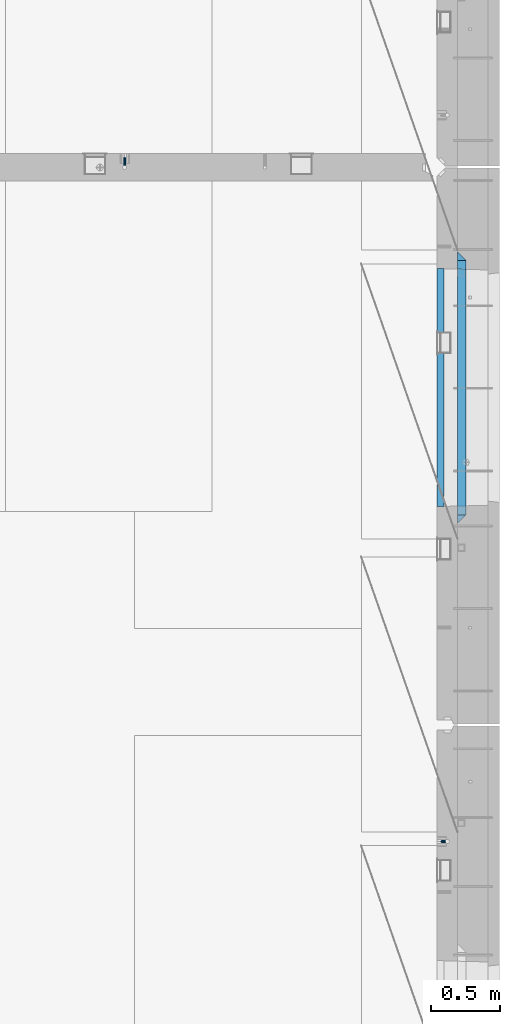
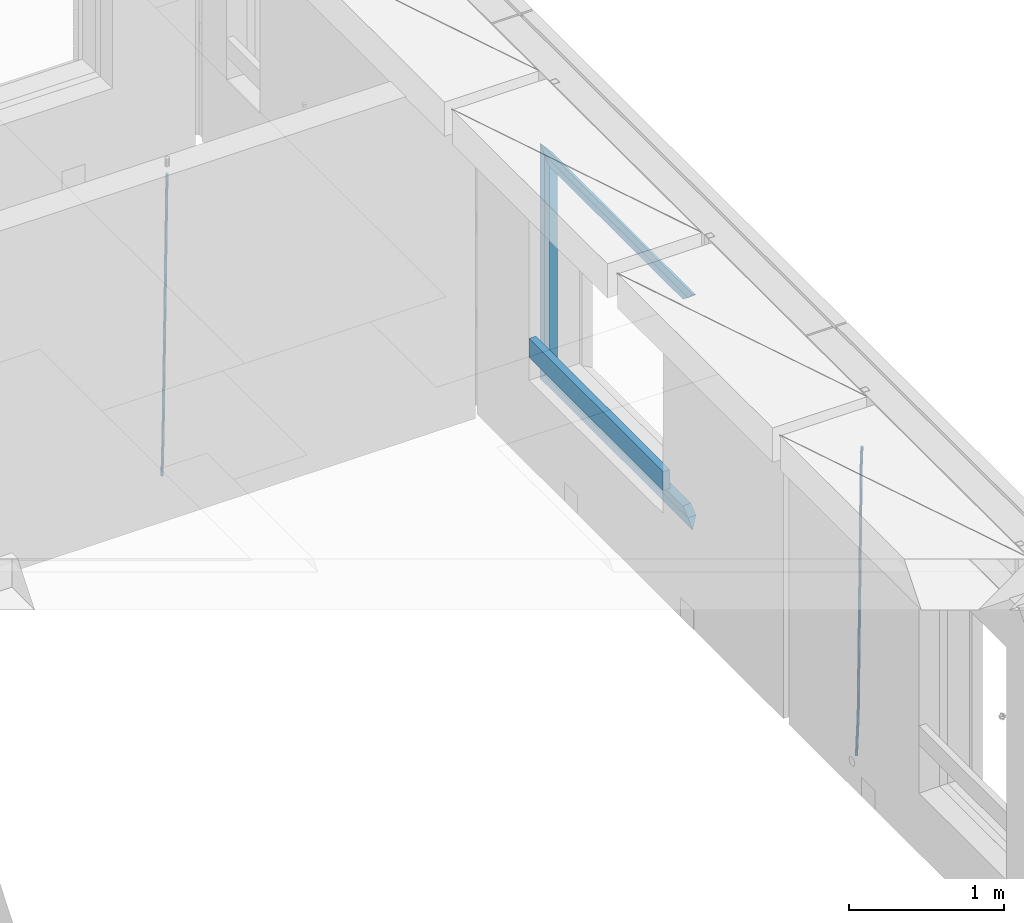
# One storey, part 132 of 350: 9 beams, 3 elements without a shape of their own.
"""IFC2X3 building model written with IfcOpenShell, lengths in millimetres."""

import ifcopenshell
import ifcopenshell.guid

model = None  # the IFC model being written
_history = None  # IfcOwnerHistory: only IFC2X3 demands one
_inside = {}  # id of a spatial element -> (the spatial element, [elements in it])
_under = {}  # id of a project, library or spatial element -> (it, [spatial elements below it])
_declared = {}  # id of a project -> (the project, [libraries it declares])
_typed = {}  # id of a type object -> (the type object, [elements of that type])
_made_of = {}  # id of a material, layer set ... -> (it, [elements and type objects made of it])


def new_model(schema):
    """Start an empty IFC model of exactly this schema.

    Asked for "IFC4X3", IfcOpenShell would pick the latest addendum, in which some entities
    have other attributes; the version numbers below select the first issue.
    IFC2X3 requires an IfcOwnerHistory on every rooted entity: one is made here for all.
    """
    global model, _history
    if schema == "IFC4X3":
        model = ifcopenshell.file(schema_version=(4, 3, 0, 0))
    else:
        model = ifcopenshell.file(schema=schema)
    _inside.clear()
    _under.clear()
    _declared.clear()
    _typed.clear()
    _made_of.clear()
    _history = None
    if model.schema == "IFC2X3":
        org = make("IfcOrganization", Name="unknown")
        user = make(
            "IfcPersonAndOrganization",
            ThePerson=make("IfcPerson", FamilyName="unknown"),
            TheOrganization=org,
        )
        app = make(
            "IfcApplication",
            ApplicationDeveloper=org,
            Version="unknown",
            ApplicationFullName="unknown",
            ApplicationIdentifier="unknown",
        )
        _history = make(
            "IfcOwnerHistory",
            OwningUser=user,
            OwningApplication=app,
            ChangeAction="ADDED",
            CreationDate=0,
        )
    return model


def make(cls, **values):
    """One entity of the class cls with the attributes given. An attribute that is None is left unset."""
    return model.create_entity(
        cls, **{name: value for name, value in values.items() if value is not None}
    )


def rooted(cls, **values):
    """An entity with a GlobalId (a new one), such as an element, a storey or a relation."""
    return make(cls, GlobalId=ifcopenshell.guid.new(), OwnerHistory=_history, **values)


def si_unit(unit_type, name, prefix=None):
    """IfcSIUnit, for example si_unit("LENGTHUNIT", "METRE", prefix="MILLI")."""
    return make("IfcSIUnit", UnitType=unit_type, Prefix=prefix, Name=name)


def assignment(units):
    """IfcUnitAssignment: the units of a project."""
    return None if units is None else make("IfcUnitAssignment", Units=units)


def point(xyz):
    """IfcCartesianPoint."""
    return None if xyz is None else make("IfcCartesianPoint", Coordinates=xyz)


def direction(xyz):
    """IfcDirection."""
    return None if xyz is None else make("IfcDirection", DirectionRatios=xyz)


def frame(location, z_axis=None, x_axis=None):
    """IfcAxis2Placement3D, a coordinate frame: its origin and axes. An axis left out is left unset."""
    return make(
        "IfcAxis2Placement3D",
        Location=point(location),
        Axis=direction(z_axis),
        RefDirection=direction(x_axis),
    )


def origin_with_axes():
    """The frame at (0, 0, 0) with the z axis (0, 0, 1) and the x axis (1, 0, 0) written out."""
    return frame((0.0, 0.0, 0.0), z_axis=(0.0, 0.0, 1.0), x_axis=(1.0, 0.0, 0.0))


def place(relative_to, where):
    """IfcLocalPlacement: puts the frame where relative to a parent placement (None: the world)."""
    return make(
        "IfcLocalPlacement", PlacementRelTo=relative_to, RelativePlacement=where
    )


def context(
    kind, dimensions, precision=None, world=None, true_north=None, identifier=None
):
    """IfcGeometricRepresentationContext, for example the 3D "Model" context."""
    return make(
        "IfcGeometricRepresentationContext",
        ContextIdentifier=identifier,
        ContextType=kind,
        CoordinateSpaceDimension=dimensions,
        Precision=precision,
        WorldCoordinateSystem=world,
        TrueNorth=true_north,
    )


def subcontext(parent, identifier, kind, view, scale=None):
    """IfcGeometricRepresentationSubContext, for example "Body" below "Model"."""
    return make(
        "IfcGeometricRepresentationSubContext",
        ContextIdentifier=identifier,
        ContextType=kind,
        ParentContext=parent,
        TargetScale=scale,
        TargetView=view,
    )


def project(units=None, contexts=None):
    """IfcProject with its units and contexts."""
    return rooted(
        "IfcProject",
        Name="project",
        RepresentationContexts=contexts,
        UnitsInContext=assignment(units),
    )


def spatial(cls, under=None, at=None, **own):
    """A site, building, storey or space (cls), placed at a placement, below another one or the project."""
    s = rooted(cls, ObjectPlacement=at, **own)
    if under is not None:
        _under.setdefault(under.id(), (under, []))[1].append(s)
    return s


def faces_of(points, faces, orient=None, outer=None):
    """IfcFace entities. A face is a list of loops; a loop is a list of indices into points, from 0.

    orient and outer hold one flag for each loop. By default every Orientation is true, the
    first loop of a face is its IfcFaceOuterBound and the others are IfcFaceBound.
    """
    made = []
    for i, loops in enumerate(faces):
        bounds = []
        for j, loop in enumerate(loops):
            is_outer = j == 0 if outer is None else outer[i][j]
            bounds.append(
                make(
                    "IfcFaceOuterBound" if is_outer else "IfcFaceBound",
                    Bound=make("IfcPolyLoop", Polygon=[points[k] for k in loop]),
                    Orientation=True if orient is None else orient[i][j],
                )
            )
        made.append(make("IfcFace", Bounds=bounds))
    return made


def faceted_brep(points, faces, orient=None, outer=None, voids=None):
    """IfcFacetedBrep: a solid bounded by flat faces; with voids (closed shells), ...WithVoids."""
    shared = [point(p) for p in points]
    hull = make("IfcClosedShell", CfsFaces=faces_of(shared, faces, orient, outer))
    if voids is None:
        return make("IfcFacetedBrep", Outer=hull)
    return make(
        "IfcFacetedBrepWithVoids",
        Outer=hull,
        Voids=[
            make(cls, CfsFaces=faces_of(shared, fs, o, b)) for cls, fs, o, b in voids
        ],
    )


def shape(context_of_items, identifier, shape_type, items):
    """IfcShapeRepresentation: the items that make up one representation, for example the "Body"."""
    return make(
        "IfcShapeRepresentation",
        ContextOfItems=context_of_items,
        RepresentationIdentifier=identifier,
        RepresentationType=shape_type,
        Items=items,
    )


def material(Name=None, Category=None):
    """IfcMaterial."""
    return make("IfcMaterial", Name=Name, Category=Category)


def made_of(thing, what):
    """Note that an element or type object is made of a material, layer set ...; save() writes the relation."""
    if what is not None:
        _made_of.setdefault(what.id(), (what, []))[1].append(thing)
    return thing


def type_object(cls, material=None, **own):
    """A type object (cls), such as IfcWallType, which elements share."""
    return made_of(rooted(cls, **own), material)


def element(
    cls,
    number,
    at=None,
    inside=None,
    cuts=None,
    type_object=None,
    material=None,
    context=None,
    identifier="Body",
    shape_type=None,
    held_by="IfcProductDefinitionShape",
    body=None,
    shapes=None,
    **own,
):
    """One element of the class cls, such as IfcWall. Its Tag is "e" and its number.

    at: its placement. inside: the storey or other place that contains it. cuts: it is an
    opening in that element (IfcRelVoidsElement). A single representation is given by context,
    identifier, shape_type and body (its items); several are given by shapes. held_by: the class
    of the entity that holds the representations. save() writes the other relations.
    """
    e = rooted(cls, Tag="e%d" % number, ObjectPlacement=at, **own)
    if body is not None:
        shapes = [shape(context, identifier, shape_type, body)]
    if shapes is not None:
        e.Representation = make(held_by, Representations=shapes)
    if inside is not None:
        _inside.setdefault(inside.id(), (inside, []))[1].append(e)
    if cuts is not None:
        rooted(
            "IfcRelVoidsElement", RelatingBuildingElement=cuts, RelatedOpeningElement=e
        )
    if type_object is not None:
        _typed.setdefault(type_object.id(), (type_object, []))[1].append(e)
    return made_of(e, material)


def aggregate(whole, parts):
    """IfcRelAggregates: a whole, such as a stair, and the parts it consists of."""
    return rooted("IfcRelAggregates", RelatingObject=whole, RelatedObjects=parts)


def save(model, path):
    """Write the relations noted so far, then the file.

    IfcRelAggregates (storeys below a building ...), IfcRelContainedInSpatialStructure (elements
    in a storey), IfcRelDefinesByType, IfcRelAssociatesMaterial and IfcRelDeclares: one each for
    every whole, place, type object, material and project.
    """
    for whole, parts in _under.values():
        aggregate(whole, parts)
    for where, things in _inside.values():
        rooted(
            "IfcRelContainedInSpatialStructure",
            RelatedElements=things,
            RelatingStructure=where,
        )
    for kind, things in _typed.values():
        rooted("IfcRelDefinesByType", RelatedObjects=things, RelatingType=kind)
    for what, things in _made_of.values():
        rooted("IfcRelAssociatesMaterial", RelatedObjects=things, RelatingMaterial=what)
    for by, libraries in _declared.values():
        rooted("IfcRelDeclares", RelatingContext=by, RelatedDefinitions=libraries)
    model.write(path)


model = new_model("IFC2X3")

# Units and contexts
model_context = context("Model", 3, precision=1e-05, world=origin_with_axes())
body_context = subcontext(model_context, "Body", "Model", "MODEL_VIEW")
ifc_project = project(units=[si_unit("LENGTHUNIT", "METRE", prefix="MILLI"), si_unit("AREAUNIT", "SQUARE_METRE"), si_unit("VOLUMEUNIT", "CUBIC_METRE"), si_unit("MASSUNIT", "GRAM", prefix="KILO"), si_unit("TIMEUNIT", "SECOND"), si_unit("PLANEANGLEUNIT", "RADIAN"), si_unit("SOLIDANGLEUNIT", "STERADIAN"), si_unit("THERMODYNAMICTEMPERATUREUNIT", "DEGREE_CELSIUS"), si_unit("LUMINOUSINTENSITYUNIT", "LUMEN")], contexts=[model_context])

# Site, building, storey
site_placement = place(None, origin_with_axes())
site = spatial("IfcSite", under=ifc_project, at=site_placement, CompositionType="ELEMENT")
building_placement = place(site_placement, origin_with_axes())
building = spatial("IfcBuilding", under=site, at=building_placement, CompositionType="ELEMENT")
storey_placement = place(building_placement, origin_with_axes())
storey = spatial("IfcBuildingStorey", under=building, at=storey_placement, Name="2", CompositionType="ELEMENT", Elevation=0.0)

# Assembly, beam
assembly_1_placement = place(storey_placement, origin_with_axes())
assembly_1 = element("IfcElementAssembly", 1, at=assembly_1_placement, inside=storey, AssemblyPlace="NOTDEFINED", PredefinedType="REINFORCEMENT_UNIT")
ifc_material_1 = material()
beam_type_1 = type_object("IfcBeamType", Name="D20", PredefinedType="NOTDEFINED")
beam_1_placement = place(assembly_1_placement, frame((32639.9999999961, 17044.9997581385, 84990.0), z_axis=(0.00020576299992186, -0.999642804629538, -0.0267249099901004), x_axis=(-4.30000201928125e-08, -0.0267249099948059, 0.999642825806181)))
beam_1 = element("IfcBeam", 2, at=beam_1_placement, type_object=beam_type_1, material=ifc_material_1, Name="JM20", ObjectType="D20", context=body_context, shape_type="Brep", body=[
    faceted_brep([(0.0, -10.0, 0.0), (-4.19531716033816e-08, -7.07106781186667, -7.07106781187031), (60.4266690400545, -7.0710677960451, -7.07106780570757), (60.4266690441291, -9.99999998418934, 6.15546014159918e-09), (0.0, 0.0, -10.0), (60.426669036824, 1.58106558956206e-08, -9.99999999384454), (4.196772351861e-08, 7.07106781186303, -7.07106781186667), (60.4266690363438, 7.07106782768096, -7.07106780570757), (0.0, 10.0, 0.0), (60.4266690388904, 10.0000000158179, 6.15182216279209e-09), (4.196772351861e-08, 7.07106781185939, 7.07106781185939), (60.4266690429649, 7.07106782768096, 7.07106781802577), (0.0, 0.0, 10.0), (60.4266690461809, 1.58179318532348e-08, 10.0000000061555), (-4.19531716033816e-08, -7.07106781187031, 7.07106781185939), (60.4266690466611, -7.07106779605238, 7.07106781802213), (61.0378400410118, -7.07106779588503, -7.07106780564936), (60.991799419251, -9.99999998403655, 6.21366780251265e-09), (61.0569027789461, 1.5985278878361e-08, -9.99999999378269), (61.0378209396877, 7.07106782784831, -7.07106780564936), (60.9917724058905, 10.0000000159635, 6.21366780251265e-09), (60.9457317841297, 7.07106782781193, 7.0710678180767), (60.9266690461809, 1.59488990902901e-08, 10.0000000062028), (60.9457508854539, -7.07106779591413, 7.0710678180767), (61.6489592143771, -7.07106614513759, -7.06310863441468), (61.5568818710308, -9.9999984576425, 0.00735959856683621), (61.6870830769039, 1.71821739058942e-06, -9.99179257185824), (61.6489210170112, 7.07106947854481, -7.06310888312146), (61.556827851804, 10.0000015422847, 0.00735924683976918), (61.4647505084577, 7.07106922979438, 7.07782747982128), (61.4266266459163, 1.36643211590126e-06, 10.0065114172685), (61.464788705809, -7.07106639389531, 7.07782772852806), (176.543135720174, -7.07075579406956, -5.56673531796696), (176.451058376813, -9.99968810657447, 1.50373291501455), (176.581259582701, 0.000312069292704109, -8.49541925541052), (176.543097522794, 7.07137982961285, -5.56673556667374), (176.451004357587, 10.00031189336, 1.50373256329476), (176.35892701424, 7.07137958085514, 8.57420079627263), (176.320803151699, 0.000311717507429421, 11.5028847337162), (176.358965211621, -7.07075604281999, 8.57420104497578), (177.098753836006, -7.07075429323595, -5.55949898843028), (176.98362511232, -9.99968666800123, 1.510669025065), (177.146421932586, 0.000313595905026887, -8.48805862247536), (177.098706077581, 7.07138133041735, -5.55949936166144), (176.983557571715, 10.0003133318824, 1.51066849724157), (176.868428848029, 7.07138095712435, 8.58083651073321), (176.820760751449, 0.000313067976094317, 11.5093961447819), (176.868476606425, -7.07075466652896, 8.58083688396073), (177.654312950661, -7.07075204110879, -5.54863964998367), (177.516135294456, -9.99968450931192, 1.52107783331303), (177.711524267797, 0.000315886711177882, -8.47701274570863), (177.654255632195, 7.07138358250813, -5.54864021007961), (177.516054233929, 10.0003154905207, 1.5210770412159), (177.377876577739, 7.0713830223176, 8.59079452451624), (177.320665260588, 0.000315094497636892, 11.5191676202448), (177.377933896176, -7.07075260129932, 8.59079508461218), (299.499456785634, -7.07025810522464, -3.16697112782276), (299.361279129444, -9.99919057342777, 3.90274635547394), (299.556668102785, 0.000809822595329024, -6.09534422354773), (299.499399467197, 7.07187751838501, -3.1669716879187), (299.361198068917, 10.0008094264049, 3.90274556338045), (299.223020412712, 7.07187695819448, 10.9724630466735), (299.165809095575, 0.000809030381788034, 13.9008361423985), (299.223077731163, -7.07025866542244, 10.9724636067695), (300.03174732349, -7.07025594743027, -3.15656661289177), (299.971788958996, -9.99918809853989, 3.91467979818117), (300.056572611924, 0.000811849109595641, -6.08557274808481), (300.031722507032, 7.07187967631762, -3.15656653768019), (299.971753863239, 10.0008119014747, 3.91467990454839), (299.91179549876, 7.07187975035777, 10.9859263156177), (299.886970210311, 0.000811953817901667, 13.9149324508144), (299.911820315203, -7.0702558733974, 10.9859262404061), (300.564137759997, -7.07025623699155, -3.15794273276697), (300.582413367199, -9.99918843065097, 3.91310145956595), (300.556570941641, 0.000811577163403854, -6.0868651410201), (300.564145451674, 7.07187938674906, -3.15794274158179), (300.582424244858, 10.0008115693345, 3.91310144710224), (300.600699852032, 7.07187937566778, 10.9841456394352), (300.608266670402, 0.000811561512819026, 13.9130680476919), (300.600692160384, -7.07025624805829, 10.98414564825), (2294.16589219622, -7.0713405251372, -8.31099358700158), (2294.1841678034, -10.0002727187966, -1.23994939466866), (2294.15832537785, -0.000272710982244462, -11.2399159952547), (2294.16589988787, 7.07079509858886, -8.31099359582004), (2294.18417868105, 9.99972728118883, -1.23994940713601), (2294.20245428824, 7.07079508752213, 5.83109478519327), (2294.2100211066, -0.00027272663282929, 8.76001719345368), (2294.20244659658, -7.07134053620393, 5.83109479401173), (2294.7782683276, -7.07134085819416, -8.31257645345977), (2294.72126025338, -10.000273010919, -1.24133766827799), (2294.84007459224, -0.000273081772320438, -11.2416781768807), (2294.87047377572, 7.07079471537872, -8.31281477453012), (2294.85165844864, 9.9997269181622, -1.24167470516841), (2294.7946503744, 7.07079476544459, 5.82956408001337), (2294.73284410976, -0.000273010977252852, 8.75866580342336), (2294.7024449263, -7.07134080815013, 5.82980240107645), (2295.39054023061, -7.0793250091956, -8.30442771922026), (2295.25826128852, -10.0072756143927, -1.23419071494573), (2295.52170777075, -0.00916171800054144, -11.2326063125765), (2295.57492774284, 7.06160849139269, -8.30343918807193), (2295.51902460904, 9.99102432676591, -1.23279272078435), (2295.38674566693, 7.06307372157607, 5.83744428349019), (2295.25557812679, -0.0070895696117077, 8.76562287684646), (2295.20235815471, -7.07785977901949, 5.83645575234186), (2317.1947101649, -7.36365585014573, -8.01423575520312), (2317.06243122277, -10.2916064553428, -0.94399875092131), (2317.32587770502, -0.293492558957951, -10.9424143485521), (2317.37909767711, 6.77727765044983, -8.01324722405116), (2317.32319454331, 9.70669348581578, -0.942600756767206), (2317.1909156012, 6.77874288063322, 6.12763624751096), (2317.05974806109, -0.291420410569117, 9.0558148408636), (2317.00652808898, -7.36219061996962, 6.12664771636264), (2317.83015404257, -7.37194216843636, -8.00577862486898), (2317.72252095213, -10.300214160583, -0.935213608652703), (2317.90419832576, -0.301033978277701, -10.9347174723516), (2317.90127966482, 6.77046829039318, -8.00629749759901), (2317.82310777172, 9.70017451494641, -0.935947405505431), (2317.71547468127, 6.77190252279979, 6.13461761071085), (2317.64143039809, -0.29900566735887, 9.06355645819713), (2317.64434905903, -7.37050793602975, 6.13513648344451), (2318.46565174212, -7.3700661537805, -7.99751648408346), (2318.38266643914, -10.2982456018653, -0.926623872735945), (2318.48256818345, -0.299336209594912, -10.9272153854981), (2318.42350634121, 6.77200652527245, -7.99954269419686), (2318.32306384158, 9.70166538090416, -0.929489366557391), (2318.2400785386, 6.77348593281204, 6.14140324480104), (2318.22316209726, -0.297244011366274, 9.07110214621207), (2318.2822239395, -7.36858674623363, 6.1434294549108), (2418.48643733139, -7.07180401323421, -6.70013846199799), (2418.4034520284, -9.99998346132634, 0.370754149349523), (2418.5033537727, -0.00107406904135132, -9.62983736341266), (2418.44429193046, 7.07026866581873, -6.70216467211139), (2418.34384943081, 9.99992752145772, 0.367888655531715), (2418.26086412782, 7.0717480733656, 7.43878126688651), (2418.24394768651, 0.00101812917273492, 10.3684801682975), (2418.30300952874, -7.07032460568735, 7.44080747699627)], [[[0, 1, 2, 3]], [[1, 4, 5, 2]], [[4, 6, 7, 5]], [[6, 8, 9, 7]], [[8, 10, 11, 9]], [[10, 12, 13, 11]], [[12, 14, 15, 13]], [[14, 0, 3, 15]], [[14, 12, 10, 8, 6, 4, 1, 0]], [[3, 2, 16, 17]], [[2, 5, 18, 16]], [[5, 7, 19, 18]], [[7, 9, 20, 19]], [[9, 11, 21, 20]], [[11, 13, 22, 21]], [[13, 15, 23, 22]], [[15, 3, 17, 23]], [[17, 16, 24, 25]], [[16, 18, 26, 24]], [[18, 19, 27, 26]], [[19, 20, 28, 27]], [[20, 21, 29, 28]], [[21, 22, 30, 29]], [[22, 23, 31, 30]], [[23, 17, 25, 31]], [[25, 24, 32, 33]], [[24, 26, 34, 32]], [[26, 27, 35, 34]], [[27, 28, 36, 35]], [[28, 29, 37, 36]], [[29, 30, 38, 37]], [[30, 31, 39, 38]], [[31, 25, 33, 39]], [[33, 32, 40, 41]], [[32, 34, 42, 40]], [[34, 35, 43, 42]], [[35, 36, 44, 43]], [[36, 37, 45, 44]], [[37, 38, 46, 45]], [[38, 39, 47, 46]], [[39, 33, 41, 47]], [[41, 40, 48, 49]], [[40, 42, 50, 48]], [[42, 43, 51, 50]], [[43, 44, 52, 51]], [[44, 45, 53, 52]], [[45, 46, 54, 53]], [[46, 47, 55, 54]], [[47, 41, 49, 55]], [[49, 48, 56, 57]], [[48, 50, 58, 56]], [[50, 51, 59, 58]], [[51, 52, 60, 59]], [[52, 53, 61, 60]], [[53, 54, 62, 61]], [[54, 55, 63, 62]], [[55, 49, 57, 63]], [[57, 56, 64, 65]], [[56, 58, 66, 64]], [[58, 59, 67, 66]], [[59, 60, 68, 67]], [[60, 61, 69, 68]], [[61, 62, 70, 69]], [[62, 63, 71, 70]], [[63, 57, 65, 71]], [[65, 64, 72, 73]], [[64, 66, 74, 72]], [[66, 67, 75, 74]], [[67, 68, 76, 75]], [[68, 69, 77, 76]], [[69, 70, 78, 77]], [[70, 71, 79, 78]], [[71, 65, 73, 79]], [[73, 72, 80, 81]], [[72, 74, 82, 80]], [[74, 75, 83, 82]], [[75, 76, 84, 83]], [[76, 77, 85, 84]], [[77, 78, 86, 85]], [[78, 79, 87, 86]], [[79, 73, 81, 87]], [[81, 80, 88, 89]], [[80, 82, 90, 88]], [[82, 83, 91, 90]], [[83, 84, 92, 91]], [[84, 85, 93, 92]], [[85, 86, 94, 93]], [[86, 87, 95, 94]], [[87, 81, 89, 95]], [[89, 88, 96, 97]], [[88, 90, 98, 96]], [[90, 91, 99, 98]], [[91, 92, 100, 99]], [[92, 93, 101, 100]], [[93, 94, 102, 101]], [[94, 95, 103, 102]], [[95, 89, 97, 103]], [[97, 96, 104, 105]], [[96, 98, 106, 104]], [[98, 99, 107, 106]], [[99, 100, 108, 107]], [[100, 101, 109, 108]], [[101, 102, 110, 109]], [[102, 103, 111, 110]], [[103, 97, 105, 111]], [[105, 104, 112, 113]], [[104, 106, 114, 112]], [[106, 107, 115, 114]], [[107, 108, 116, 115]], [[108, 109, 117, 116]], [[109, 110, 118, 117]], [[110, 111, 119, 118]], [[111, 105, 113, 119]], [[113, 112, 120, 121]], [[112, 114, 122, 120]], [[114, 115, 123, 122]], [[115, 116, 124, 123]], [[116, 117, 125, 124]], [[117, 118, 126, 125]], [[118, 119, 127, 126]], [[119, 113, 121, 127]], [[121, 120, 128, 129]], [[120, 122, 130, 128]], [[122, 123, 131, 130]], [[123, 124, 132, 131]], [[124, 125, 133, 132]], [[125, 126, 134, 133]], [[126, 127, 135, 134]], [[127, 121, 129, 135]], [[130, 131, 132, 133, 134, 135, 129, 128]]]),
])
aggregate(assembly_1, [beam_1])

assembly_2_placement = place(storey_placement, origin_with_axes())
assembly_2 = element("IfcElementAssembly", 3, at=assembly_2_placement, inside=storey, AssemblyPlace="NOTDEFINED", PredefinedType="REINFORCEMENT_UNIT")
beam_2_placement = place(assembly_2_placement, frame((34944.9999977209, 12080.9402860984, 84990.0), z_axis=(0.999642804629538, 0.000205762999925497, -0.0267249099901003), x_axis=(0.0267249109941254, -4.30000210532798e-08, 0.999642825779465)))
beam_2 = element("IfcBeam", 4, at=beam_2_placement, type_object=beam_type_1, material=ifc_material_1, Name="JM20", ObjectType="D20", context=body_context, shape_type="Brep", body=[
    faceted_brep([(0.0, -10.0, 0.0), (-4.19531716033816e-08, -7.07106781186667, -7.07106781187031), (60.4266690400545, -7.0710677960451, -7.07106780570757), (60.4266690441291, -9.99999998418934, 6.15546014159918e-09), (0.0, 0.0, -10.0), (60.426669036824, 1.58106558956206e-08, -9.99999999384454), (4.196772351861e-08, 7.07106781186303, -7.07106781186667), (60.4266690363438, 7.07106782768096, -7.07106780570757), (0.0, 10.0, 0.0), (60.4266690388904, 10.0000000158179, 6.15182216279209e-09), (4.196772351861e-08, 7.07106781185939, 7.07106781185939), (60.4266690429649, 7.07106782768096, 7.07106781802577), (0.0, 0.0, 10.0), (60.4266690461809, 1.58179318532348e-08, 10.0000000061555), (-4.19531716033816e-08, -7.07106781187031, 7.07106781185939), (60.4266690466611, -7.07106779605238, 7.07106781802213), (61.0378400410118, -7.07106779588503, -7.07106780564936), (60.991799419251, -9.99999998403655, 6.21366780251265e-09), (61.0569027789461, 1.5985278878361e-08, -9.99999999378269), (61.0378209396877, 7.07106782784831, -7.07106780564936), (60.9917724058905, 10.0000000159635, 6.21366780251265e-09), (60.9457317841297, 7.07106782781193, 7.0710678180767), (60.9266690461809, 1.59488990902901e-08, 10.0000000062028), (60.9457508854539, -7.07106779591413, 7.0710678180767), (61.6489592143771, -7.07106614513759, -7.06310863441468), (61.5568818710308, -9.9999984576425, 0.00735959856683621), (61.6870830769039, 1.71821739058942e-06, -9.99179257185824), (61.6489210170112, 7.07106947854481, -7.06310888312146), (61.556827851804, 10.0000015422847, 0.00735924683976918), (61.4647505084577, 7.07106922979438, 7.07782747982128), (61.4266266459163, 1.36643211590126e-06, 10.0065114172685), (61.464788705809, -7.07106639389531, 7.07782772852806), (176.543135720174, -7.07075579406956, -5.56673531796696), (176.451058376813, -9.99968810657447, 1.50373291501455), (176.581259582701, 0.000312069292704109, -8.49541925541052), (176.543097522794, 7.07137982961285, -5.56673556667374), (176.451004357587, 10.00031189336, 1.50373256329476), (176.35892701424, 7.07137958085514, 8.57420079627263), (176.320803151699, 0.000311717507429421, 11.5028847337162), (176.358965211621, -7.07075604281999, 8.57420104497578), (177.098753836006, -7.07075429323595, -5.55949898843028), (176.98362511232, -9.99968666800123, 1.510669025065), (177.146421932586, 0.000313595905026887, -8.48805862247536), (177.098706077581, 7.07138133041735, -5.55949936166144), (176.983557571715, 10.0003133318824, 1.51066849724157), (176.868428848029, 7.07138095712435, 8.58083651073321), (176.820760751449, 0.000313067976094317, 11.5093961447819), (176.868476606425, -7.07075466652896, 8.58083688396073), (177.654312950661, -7.07075204110879, -5.54863964998367), (177.516135294456, -9.99968450931192, 1.52107783331303), (177.711524267797, 0.000315886711177882, -8.47701274570863), (177.654255632195, 7.07138358250813, -5.54864021007961), (177.516054233929, 10.0003154905207, 1.5210770412159), (177.377876577739, 7.0713830223176, 8.59079452451624), (177.320665260588, 0.000315094497636892, 11.5191676202448), (177.377933896176, -7.07075260129932, 8.59079508461218), (299.436796249574, -7.07025836271714, -3.1681962331204), (299.298618593355, -9.99919083092027, 3.90152125031091), (299.494007566798, 0.000809565110102994, -6.09656932889993), (299.436738931283, 7.07187726089978, -3.16819679320906), (299.298537533061, 10.0008091689197, 3.90152045822106), (299.160359876842, 7.07187670072017, 10.9712379416487), (299.103148559603, 0.000808772889286047, 13.8996110374392), (299.160417195119, -7.07025892290039, 10.9712385017483), (299.98743051647, -7.07025613056248, -3.15743315966392), (299.971788958996, -9.99918809853989, 3.91467979818117), (299.993912075952, 0.000811591617093654, -6.08679785393178), (299.987423933868, 7.07187949325817, -3.1574327280432), (299.971753863239, 10.0008119014747, 3.91467990454839), (299.95611230444, 7.07187992653053, 10.9867922621015), (299.949630744944, 0.000812204350950196, 13.9161569563694), (299.956118887014, -7.07025569729012, 10.9867918304735), (300.538107039494, -7.07025785017686, -3.16575821840888), (300.644985195438, -9.99919020432935, 3.90450175465594), (300.493854948218, 0.000810030429420294, -6.09435592770024), (300.538151196495, 7.071877773491, -3.16575855385963), (300.645047642858, 10.0008097955724, 3.90450128024895), (300.751925798773, 7.07187744142357, 10.9747612533101), (300.796177890064, 0.000809560813650023, 13.9033589625978), (300.751881641787, -7.07025818224065, 10.9747615887682), (2293.36490490142, -7.07648090940347, -33.2930642912361), (2293.47178305736, -10.0054132635523, -26.2228043181785), (2293.32065281013, -0.00541302880083094, -36.2216620005347), (2293.36494905842, 7.06565471425711, -33.2930646266868), (2293.47184550477, 9.99458673634581, -26.2228047925819), (2293.57872366071, 7.06565438219332, -19.1525448195243), (2293.62297575199, -0.00541349841296324, -16.2239471102366), (2293.57867950371, -7.0764812414709, -19.1525444840736), (2294.0658245362, -7.07648309818615, -33.3036607065333), (2294.05312277409, -10.0054150789219, -26.2315929392535), (2294.10928714235, -0.00541549149056664, -36.2335844756526), (2294.15805078732, 7.06565223761572, -33.3050546393533), (2294.18355038921, 9.99458451388637, -26.2335642579346), (2294.17084862708, 7.06565253314329, -19.1614964906439), (2294.12738602093, -0.00541507354500936, -16.2315727215355), (2294.07862237596, -7.07648280265857, -19.1601025578348), (2294.76670261032, -7.08562269121467, -33.294332712383), (2294.63442802057, -10.0129954178956, -26.2238563411993), (2294.89787471293, -0.0156988342423574, -36.2230891548279), (2294.95110548967, 7.05531064255774, -33.2944998654275), (2294.89521307347, 9.98530428734011, -26.2240927312887), (2294.76293848372, 7.0579315606592, -19.1536163601049), (2294.63176638114, -0.0119922963167483, -16.2248599176673), (2294.57853560438, -7.08300177311321, -19.1534492070678), (2316.52657204497, -7.36937582653991, -33.0047303660212), (2316.39429745522, -10.2967485532172, -25.9342539948302), (2316.65774414754, -0.299451969567599, -35.9334868084661), (2316.7109749243, 6.7715575072325, -33.0048975190657), (2316.65508250811, 9.70155115201487, -25.9344903849269), (2316.52280791836, 6.7741784253376, -18.8640140137468), (2316.39163581574, -0.295745431634714, -15.9352575713092), (2316.33840503903, -7.36675490843481, -18.863846860706), (2317.16202064224, -7.37766220584308, -32.9962731735213), (2317.05438744847, -10.3053562613532, -25.9254688497131), (2317.23607125619, -0.306993473008333, -35.925789846493), (2317.23316144495, 6.76474808850253, -32.9979477328052), (2317.15499573652, 9.6950321815566, -25.9278370341635), (2317.04736254275, 6.7673381260538, -18.8570327103698), (2316.97331192881, -0.303330606784584, -15.9275160373909), (2316.97622174003, -7.37507216829545, -18.8553581510787), (2317.79752306276, -7.37578610372293, -32.9880110666527), (2317.71453320107, -10.3033876998124, -25.9168792378296), (2317.81444760226, -0.305295583297266, -35.918287695793), (2317.75539265381, 6.76628640723357, -32.9911928173897), (2317.65495180529, 9.69652304524061, -25.9213789128698), (2317.5719619436, 6.76892144914746, -18.8502470840467), (2317.55503740412, -0.301569071270933, -15.9199704549137), (2317.61409235255, -7.3731510618054, -18.847065333317), (2417.8183084176, -7.07752398473531, -31.6906369377139), (2417.73531855589, -10.0051255808248, -24.6195051088798), (2417.83523295709, -0.007033464313281, -34.6209135668432), (2417.77617800863, 7.06454852621755, -31.6938186884508), (2417.67573716014, 9.99478516423187, -24.6240047839383), (2417.59274729842, 7.06718356813872, -17.5528729551006), (2417.57582275895, -0.00330695228694822, -14.6225963259749), (2417.6348777074, -7.07488894281778, -17.5496912043673)], [[[0, 1, 2, 3]], [[1, 4, 5, 2]], [[4, 6, 7, 5]], [[6, 8, 9, 7]], [[8, 10, 11, 9]], [[10, 12, 13, 11]], [[12, 14, 15, 13]], [[14, 0, 3, 15]], [[14, 12, 10, 8, 6, 4, 1, 0]], [[3, 2, 16, 17]], [[2, 5, 18, 16]], [[5, 7, 19, 18]], [[7, 9, 20, 19]], [[9, 11, 21, 20]], [[11, 13, 22, 21]], [[13, 15, 23, 22]], [[15, 3, 17, 23]], [[17, 16, 24, 25]], [[16, 18, 26, 24]], [[18, 19, 27, 26]], [[19, 20, 28, 27]], [[20, 21, 29, 28]], [[21, 22, 30, 29]], [[22, 23, 31, 30]], [[23, 17, 25, 31]], [[25, 24, 32, 33]], [[24, 26, 34, 32]], [[26, 27, 35, 34]], [[27, 28, 36, 35]], [[28, 29, 37, 36]], [[29, 30, 38, 37]], [[30, 31, 39, 38]], [[31, 25, 33, 39]], [[33, 32, 40, 41]], [[32, 34, 42, 40]], [[34, 35, 43, 42]], [[35, 36, 44, 43]], [[36, 37, 45, 44]], [[37, 38, 46, 45]], [[38, 39, 47, 46]], [[39, 33, 41, 47]], [[41, 40, 48, 49]], [[40, 42, 50, 48]], [[42, 43, 51, 50]], [[43, 44, 52, 51]], [[44, 45, 53, 52]], [[45, 46, 54, 53]], [[46, 47, 55, 54]], [[47, 41, 49, 55]], [[49, 48, 56, 57]], [[48, 50, 58, 56]], [[50, 51, 59, 58]], [[51, 52, 60, 59]], [[52, 53, 61, 60]], [[53, 54, 62, 61]], [[54, 55, 63, 62]], [[55, 49, 57, 63]], [[57, 56, 64, 65]], [[56, 58, 66, 64]], [[58, 59, 67, 66]], [[59, 60, 68, 67]], [[60, 61, 69, 68]], [[61, 62, 70, 69]], [[62, 63, 71, 70]], [[63, 57, 65, 71]], [[65, 64, 72, 73]], [[64, 66, 74, 72]], [[66, 67, 75, 74]], [[67, 68, 76, 75]], [[68, 69, 77, 76]], [[69, 70, 78, 77]], [[70, 71, 79, 78]], [[71, 65, 73, 79]], [[73, 72, 80, 81]], [[72, 74, 82, 80]], [[74, 75, 83, 82]], [[75, 76, 84, 83]], [[76, 77, 85, 84]], [[77, 78, 86, 85]], [[78, 79, 87, 86]], [[79, 73, 81, 87]], [[81, 80, 88, 89]], [[80, 82, 90, 88]], [[82, 83, 91, 90]], [[83, 84, 92, 91]], [[84, 85, 93, 92]], [[85, 86, 94, 93]], [[86, 87, 95, 94]], [[87, 81, 89, 95]], [[89, 88, 96, 97]], [[88, 90, 98, 96]], [[90, 91, 99, 98]], [[91, 92, 100, 99]], [[92, 93, 101, 100]], [[93, 94, 102, 101]], [[94, 95, 103, 102]], [[95, 89, 97, 103]], [[97, 96, 104, 105]], [[96, 98, 106, 104]], [[98, 99, 107, 106]], [[99, 100, 108, 107]], [[100, 101, 109, 108]], [[101, 102, 110, 109]], [[102, 103, 111, 110]], [[103, 97, 105, 111]], [[105, 104, 112, 113]], [[104, 106, 114, 112]], [[106, 107, 115, 114]], [[107, 108, 116, 115]], [[108, 109, 117, 116]], [[109, 110, 118, 117]], [[110, 111, 119, 118]], [[111, 105, 113, 119]], [[113, 112, 120, 121]], [[112, 114, 122, 120]], [[114, 115, 123, 122]], [[115, 116, 124, 123]], [[116, 117, 125, 124]], [[117, 118, 126, 125]], [[118, 119, 127, 126]], [[119, 113, 121, 127]], [[121, 120, 128, 129]], [[120, 122, 130, 128]], [[122, 123, 131, 130]], [[123, 124, 132, 131]], [[124, 125, 133, 132]], [[125, 126, 134, 133]], [[126, 127, 135, 134]], [[127, 121, 129, 135]], [[130, 131, 132, 133, 134, 135, 129, 128]]]),
])
aggregate(assembly_2, [beam_2])

# Assembly, beams
assembly_3_placement = place(storey_placement, origin_with_axes())
assembly_3 = element("IfcElementAssembly", 5, at=assembly_3_placement, inside=storey, AssemblyPlace="NOTDEFINED", PredefinedType="REINFORCEMENT_UNIT")
ifc_material_2 = material(Name="TIMBER/T24")
beam_type_2 = type_object("IfcBeamType", PredefinedType="NOTDEFINED")
beam_3_placement = place(assembly_3_placement, frame((34935.0002758707, 14515.0011884524, 85685.0), z_axis=(0.0, 0.0, 1.0), x_axis=(0.0, 1.0, 0.0)))
beam_3 = element("IfcBeam", 6, at=beam_3_placement, type_object=beam_type_2, material=ifc_material_2, context=body_context, shape_type="Brep", body=[
    faceted_brep([(-3.63797880709171e-12, 24.9999999999964, -75.0), (-3.63797880709171e-12, 24.9999999999964, 75.0), (1730.0, 25.0, 75.0), (1730.0, 25.0, -75.0), (0.0, -25.0000000000073, 75.0), (1730.0, -25.0, 75.0), (0.0, -25.0000000000073, -75.0), (1730.0, -25.0, -75.0)], [[[0, 1, 2, 3]], [[1, 4, 5, 2]], [[4, 6, 7, 5]], [[6, 0, 3, 7]], [[5, 7, 3, 2]], [[6, 4, 1, 0]]]),
])
ifc_material_3 = material(Name="CONCRETE/C25/30")
beam_type_3 = type_object("IfcBeamType", PredefinedType="NOTDEFINED")
beam_4_placement = place(assembly_3_placement, frame((35090.0, 14394.9995850056, 87145.0), z_axis=(0.0, 0.0, -1.0), x_axis=(0.0, 1.0, 0.0)))
beam_4 = element("IfcBeam", 7, at=beam_4_placement, type_object=beam_type_3, material=ifc_material_3, Name="SK", context=body_context, shape_type="Brep", body=[
    faceted_brep([(60.0000000000073, 30.0, 30.0), (0.0, -30.0, -30.0), (60.0000000000073, -30.0, 30.0), (1910.00076293945, 30.0, 30.0), (1970.00076293945, -30.0, -30.0), (1910.00076293945, -30.0, 30.0)], [[[0, 1, 2]], [[1, 0, 3, 4]], [[2, 1, 4, 5]], [[0, 2, 5, 3]], [[4, 3, 5]]]),
])
beam_5_placement = place(assembly_3_placement, frame((35090.0, 14454.9995850056, 87085.0), z_axis=(0.0, 0.0, -1.0), x_axis=(0.0, 1.0, 0.0)))
beam_5 = element("IfcBeam", 8, at=beam_5_placement, type_object=beam_type_3, material=ifc_material_3, Name="SK", context=body_context, shape_type="Brep", body=[
    faceted_brep([(1785.9467088854, -30.0, 24.0540540540533), (1784.32508726378, 30.0, 25.6756756756804), (65.6764386151262, 30.0, 25.6756756756804), (64.0548169935064, -30.0, 24.0540540540533), (65.6764386151262, 30.0, 26.294090229203), (64.0548169935064, -30.0, 24.9041288395529), (0.0, 30.0, -30.0), (0.0, -30.0, -30.0), (1850.00076293945, 30.0, -30.0), (1850.00076293945, -30.0, -30.0), (1785.9467088854, -30.0, 24.9034748914128), (1784.32508726378, 30.0, 26.2934362810774)], [[[0, 1, 2, 3]], [[3, 2, 4, 5]], [[5, 4, 6, 7]], [[7, 6, 8, 9]], [[0, 3, 5, 7, 9, 10]], [[1, 0, 10, 11]], [[6, 4, 2, 1, 11, 8]], [[9, 8, 11, 10]]]),
])
beam_6_placement = place(assembly_3_placement, frame((35090.0, 16335.0003479451, 87175.0), z_axis=(0.0, -1.0, 0.0), x_axis=(0.0, 0.0, -1.0)))
beam_6 = element("IfcBeam", 9, at=beam_6_placement, type_object=beam_type_3, material=ifc_material_3, Name="SK", context=body_context, shape_type="Brep", body=[
    faceted_brep([(60.0000000000073, 30.0, 30.0), (0.0, -30.0, -30.0), (60.0000000000073, -30.0, 30.0), (1795.00000000001, 30.0, 30.0), (1855.0, -30.0, -30.0), (1795.00000000001, -30.0, 30.0)], [[[0, 1, 2]], [[3, 4, 1, 0]], [[4, 5, 2, 1]], [[5, 3, 0, 2]], [[5, 4, 3]]]),
])
beam_7_placement = place(assembly_3_placement, frame((35090.0, 16305.0003479451, 85410.0), z_axis=(0.0, 0.0, 1.0), x_axis=(0.0, -1.0, 0.0)))
beam_7 = element("IfcBeam", 10, at=beam_7_placement, type_object=beam_type_3, material=ifc_material_3, Name="SK", context=body_context, shape_type="Brep", body=[
    faceted_brep([(1785.94594594595, -30.0, 24.0540540540533), (1784.32432432433, 30.0, 25.6756756756804), (65.6756756756768, 30.0, 25.6756756756804), (64.0540540540533, -30.0, 24.0540540540533), (1785.94594594595, -30.0, 24.9041288395238), (1784.32432432433, 30.0, 26.2940902291739), (1850.00076293945, -30.0, -30.0), (1850.00076293945, 30.0, -30.0), (0.0, 30.0, -30.0), (65.6756756756768, 30.0, 26.293436281092), (64.0540540540533, -30.0, 24.9034748914419), (0.0, -30.0, -30.0)], [[[0, 1, 2, 3]], [[1, 0, 4, 5]], [[4, 6, 7, 5]], [[2, 1, 5, 7, 8, 9]], [[3, 2, 9, 10]], [[6, 4, 0, 3, 10, 11]], [[11, 8, 7, 6]], [[11, 10, 9, 8]]]),
])
beam_8_placement = place(assembly_3_placement, frame((35090.0, 16365.0003479451, 85350.0), z_axis=(0.0, 0.0, 1.0), x_axis=(0.0, -1.0, 0.0)))
beam_8 = element("IfcBeam", 11, at=beam_8_placement, type_object=beam_type_3, material=ifc_material_3, Name="SK", context=body_context, shape_type="Brep", body=[
    faceted_brep([(1970.00076293945, -30.0, -30.0), (1910.00076293945, 30.0, 30.0), (1910.00076293945, -30.0, 30.0), (60.0000000000073, 30.0, 30.0), (60.0000000000073, -30.0, 30.0), (0.0, -30.0, -30.0)], [[[0, 1, 2]], [[3, 4, 2, 1]], [[4, 5, 0, 2]], [[5, 3, 1, 0]], [[3, 5, 4]]]),
])
beam_type_4 = type_object("IfcBeamType", PredefinedType="NOTDEFINED")
beam_9_placement = place(assembly_3_placement, frame((35090.0, 16270.0003479451, 87115.0), z_axis=(0.0, -1.0, 0.0), x_axis=(0.0, 0.0, -1.0)))
beam_9 = element("IfcBeam", 12, at=beam_9_placement, type_object=beam_type_4, material=ifc_material_3, Name="SK", context=body_context, shape_type="Brep", body=[
    faceted_brep([(0.0, -30.0, -35.0), (54.9034748914273, -30.0, 29.0540540540533), (56.2934362811066, 30.0, 30.6756756756768), (0.0, 30.0, -35.0), (1735.0, 30.0, -35.0), (1735.0, -30.0, -35.0), (1680.09652510857, -30.0, 29.0540540540533), (1678.70656371891, 30.0, 30.6756756756768)], [[[0, 1, 2, 3]], [[4, 5, 0, 3]], [[1, 0, 5, 6]], [[2, 1, 6, 7]], [[3, 2, 7, 4]], [[5, 4, 7, 6]]]),
])
aggregate(assembly_3, [beam_3, beam_4, beam_5, beam_6, beam_9, beam_7, beam_8])

save(model, "model.ifc")
